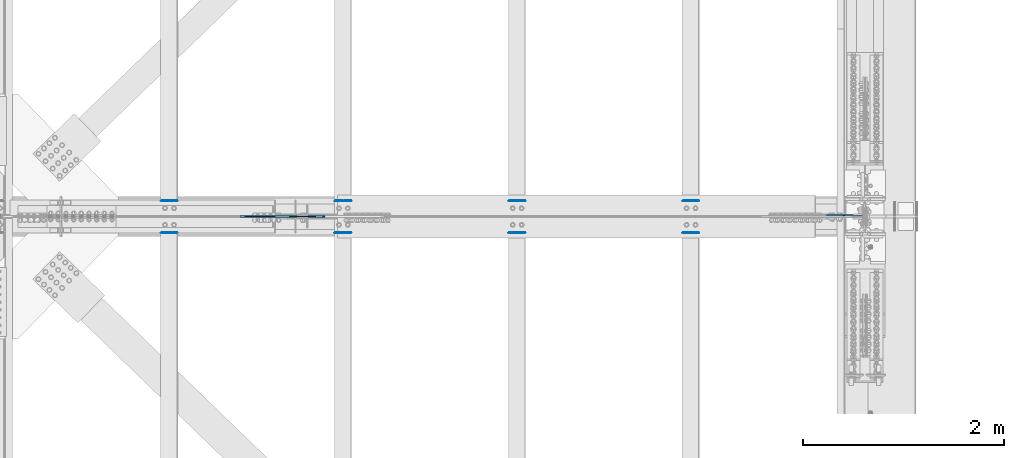
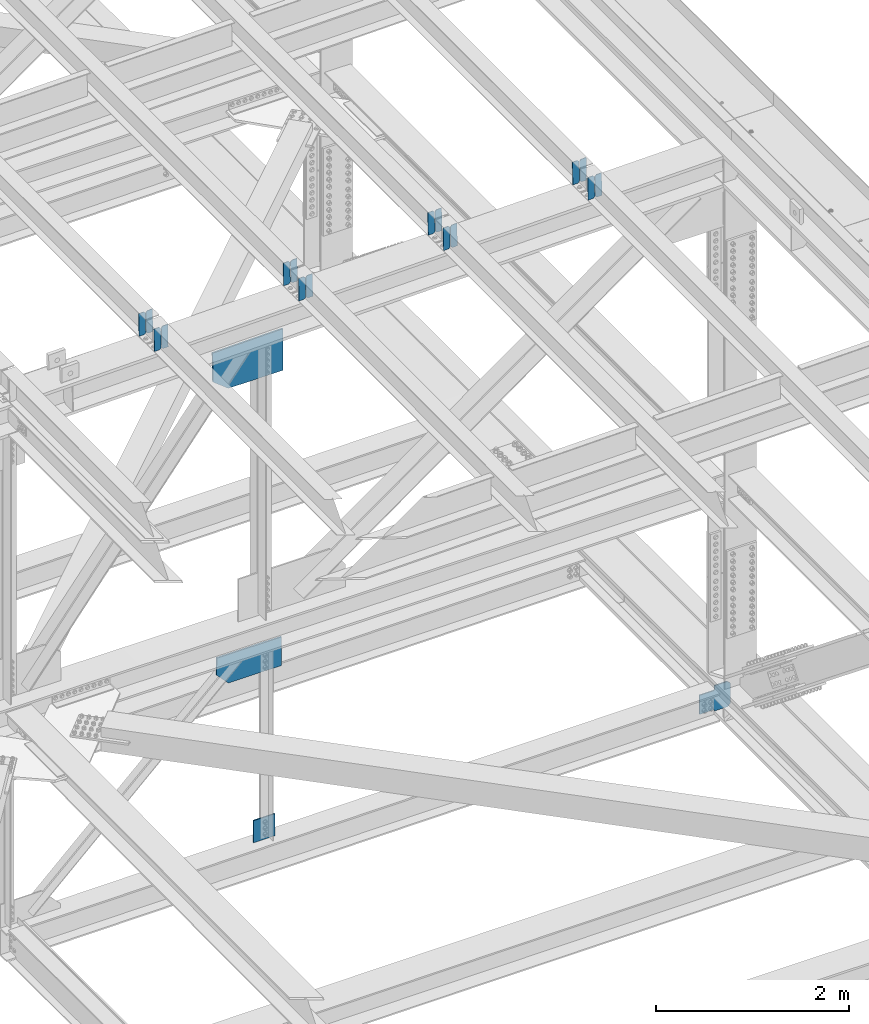
# One storey, part 3592 of 3843: 20 plates, 12 elements without a shape of their own.
"""IFC2X3 building model written with IfcOpenShell, lengths in millimetres."""

from ifc_helpers import new_model, si_unit, frame, origin_with_axes, place, context, subcontext, project, spatial, faceted_brep, material, type_object, element, aggregate, save


model = new_model("IFC2X3")

# Units and contexts
model_context = context("Model", 3, precision=1e-05, world=origin_with_axes())
body_context = subcontext(model_context, "Body", "Model", "MODEL_VIEW")
ifc_project = project(units=[si_unit("LENGTHUNIT", "METRE", prefix="MILLI"), si_unit("AREAUNIT", "SQUARE_METRE"), si_unit("VOLUMEUNIT", "CUBIC_METRE"), si_unit("MASSUNIT", "GRAM", prefix="KILO"), si_unit("TIMEUNIT", "SECOND"), si_unit("PLANEANGLEUNIT", "RADIAN"), si_unit("SOLIDANGLEUNIT", "STERADIAN"), si_unit("THERMODYNAMICTEMPERATUREUNIT", "DEGREE_CELSIUS"), si_unit("LUMINOUSINTENSITYUNIT", "LUMEN")], contexts=[model_context])

# Site, building, storey
site_placement = place(None, origin_with_axes())
site = spatial("IfcSite", under=ifc_project, at=site_placement, CompositionType="ELEMENT")
building_placement = place(site_placement, origin_with_axes())
building = spatial("IfcBuilding", under=site, at=building_placement, Name="Undefined", CompositionType="ELEMENT")
storey_placement = place(building_placement, origin_with_axes())
storey = spatial("IfcBuildingStorey", under=building, at=storey_placement, Name="Undefined", CompositionType="ELEMENT", Elevation=0.0)

# Assembly, plates
assembly_1_placement = place(storey_placement, origin_with_axes())
assembly_1 = element("IfcElementAssembly", 1, at=assembly_1_placement, inside=storey, Name="BEAM", AssemblyPlace="NOTDEFINED", PredefinedType="RIGID_FRAME")
ifc_material = material(Name="STEEL/A572-50")
plate_type_1 = type_object("IfcPlateType", PredefinedType="NOTDEFINED")
plate_1_placement = place(assembly_1_placement, frame((80549.4964783678, 42358.3199648956, 46426.5926528859), z_axis=(-0.0211520975879684, -0.0021646719998389, 0.999773925926638), x_axis=(-0.999776269348977, 4.5491000049241e-05, -0.0211520490073722)))
plate_1 = element("IfcPlate", 2, at=plate_1_placement, type_object=plate_type_1, material=ifc_material, Name="PLATE", context=body_context, shape_type="Brep", body=[
    faceted_brep([(0.0, -3.17499999999927, 0.0), (6.83940015733242e-10, -3.17499999996653, 288.924999998613), (6.54836185276508e-10, 3.17500000001746, 288.924999998591), (0.0, 3.17499999999927, 0.0), (60.3250007643655, -3.17500000017753, 288.924999998606), (60.3250007643219, 3.17499999979918, 288.924999998584), (79.3750000013097, -3.17500000025029, 269.875000761494), (79.375000001266, 3.17499999972642, 269.875000761487), (79.375000000713, -3.17500000026484, 19.0499992370605), (79.3750000006985, 3.17499999971187, 19.0499992370533), (60.325000763667, -3.17500000020664, -1.45519152283669e-11), (60.3250007636234, 3.17499999977736, -3.63797880709171e-11)], [[[0, 1, 2, 3]], [[1, 4, 5, 2]], [[4, 6, 7, 5]], [[6, 8, 9, 7]], [[8, 10, 11, 9]], [[10, 0, 3, 11]], [[5, 7, 9, 11, 3, 2]], [[10, 8, 6, 4, 1, 0]]]),
])
plate_2_placement = place(assembly_1_placement, frame((80463.7906576766, 42358.3238908933, 46424.7793935353), z_axis=(-0.0211520975879684, -0.0021646719998389, 0.999773925926638), x_axis=(-0.999776269348977, 4.5491000049241e-05, -0.0211520490073722)))
plate_2 = element("IfcPlate", 3, at=plate_2_placement, type_object=plate_type_1, material=ifc_material, Name="PLATE", context=body_context, shape_type="Brep", body=[
    faceted_brep([(4.36557456851006e-11, -3.17499999998836, 19.0499992370969), (6.11180439591408e-10, -3.17499999996653, 269.875000761516), (5.96628524363041e-10, 3.17500000001746, 269.875000761502), (1.45519152283669e-11, 3.17499999998836, 19.0499992370824), (19.0499992376572, -3.17500000003201, 288.924999998606), (19.0499992376281, 3.1749999999447, 288.924999998584), (79.3750000013242, -3.17500000025029, 288.924999998591), (79.3750000013097, 3.1749999997337, 288.92499999857), (79.3750000006548, -3.17500000026484, -2.18278728425503e-11), (79.3750000006403, 3.17499999969732, -2.91038304567337e-11), (19.0499992370023, -3.17500000005384, 0.0), (19.0499992369587, 3.17499999992287, -1.45519152283669e-11)], [[[0, 1, 2, 3]], [[1, 4, 5, 2]], [[4, 6, 7, 5]], [[6, 8, 9, 7]], [[8, 10, 11, 9]], [[10, 0, 3, 11]], [[5, 7, 9, 11, 3, 2]], [[10, 8, 6, 4, 1, 0]]]),
])
aggregate(assembly_1, [plate_1, plate_2])

assembly_2_placement = place(storey_placement, origin_with_axes())
assembly_2 = element("IfcElementAssembly", 4, at=assembly_2_placement, inside=storey, Name="BEAM", AssemblyPlace="NOTDEFINED", PredefinedType="RIGID_FRAME")
plate_3_placement = place(assembly_2_placement, frame((80549.4964783593, 42041.8168577056, 46425.3747151897), z_axis=(-0.0211520976960747, -0.00548809500152129, 0.999761206276934), x_axis=(-0.999776269345233, 0.000116185000071389, -0.0211517790072879)))
plate_3 = element("IfcPlate", 5, at=plate_3_placement, type_object=plate_type_1, material=ifc_material, Name="PLATE", context=body_context, shape_type="Brep", body=[
    faceted_brep([(0.0, -3.17499999999927, 0.0), (6.83940015733242e-10, -3.17499999996653, 288.924999998613), (6.54836185276508e-10, 3.17500000001746, 288.924999998591), (0.0, 3.17499999999927, 0.0), (60.3250007643655, -3.17500000017753, 288.924999998606), (60.3250007643219, 3.17499999979918, 288.924999998584), (79.3750000013097, -3.17500000025029, 269.875000761494), (79.375000001266, 3.17499999972642, 269.875000761487), (79.375000000713, -3.17500000026484, 19.0499992370605), (79.3750000006985, 3.17499999971187, 19.0499992370533), (60.325000763667, -3.17500000020664, -1.45519152283669e-11), (60.3250007636234, 3.17499999977736, -3.63797880709171e-11)], [[[0, 1, 2, 3]], [[1, 4, 5, 2]], [[4, 6, 7, 5]], [[6, 8, 9, 7]], [[8, 10, 11, 9]], [[10, 0, 3, 11]], [[5, 7, 9, 11, 3, 2]], [[10, 8, 6, 4, 1, 0]]]),
])
plate_4_placement = place(assembly_2_placement, frame((80463.790657668, 42041.8268112952, 46423.5614789073), z_axis=(-0.0211520976960747, -0.00548809500152129, 0.999761206276934), x_axis=(-0.999776269345233, 0.000116185000071389, -0.0211517790072879)))
plate_4 = element("IfcPlate", 6, at=plate_4_placement, type_object=plate_type_1, material=ifc_material, Name="PLATE", context=body_context, shape_type="Brep", body=[
    faceted_brep([(4.36557456851006e-11, -3.17499999998836, 19.0499992370969), (6.11180439591408e-10, -3.17499999996653, 269.875000761516), (5.96628524363041e-10, 3.17500000001746, 269.875000761502), (1.45519152283669e-11, 3.17499999998836, 19.0499992370824), (19.0499992376572, -3.17500000003201, 288.924999998606), (19.0499992376281, 3.1749999999447, 288.924999998584), (79.3750000013242, -3.17500000025029, 288.924999998591), (79.3750000013097, 3.1749999997337, 288.92499999857), (79.3750000006548, -3.17500000026484, -2.18278728425503e-11), (79.3750000006403, 3.17499999969732, -2.91038304567337e-11), (19.0499992370023, -3.17500000005384, 0.0), (19.0499992369587, 3.17499999992287, -1.45519152283669e-11)], [[[0, 1, 2, 3]], [[1, 4, 5, 2]], [[4, 6, 7, 5]], [[6, 8, 9, 7]], [[8, 10, 11, 9]], [[10, 0, 3, 11]], [[5, 7, 9, 11, 3, 2]], [[10, 8, 6, 4, 1, 0]]]),
])
aggregate(assembly_2, [plate_3, plate_4])

assembly_3_placement = place(storey_placement, origin_with_axes())
assembly_3 = element("IfcElementAssembly", 7, at=assembly_3_placement, inside=storey, Name="BEAM", AssemblyPlace="NOTDEFINED", PredefinedType="RIGID_FRAME")
plate_5_placement = place(assembly_3_placement, frame((84003.8964783664, 42358.3091470326, 46491.0935122298), z_axis=(-0.0211520979367197, -0.00212832399991021, 0.999774003957808), x_axis=(-0.999776269348977, 4.5491000049241e-05, -0.0211520490073722)))
plate_5 = element("IfcPlate", 8, at=plate_5_placement, type_object=plate_type_1, material=ifc_material, Name="PLATE", context=body_context, shape_type="Brep", body=[
    faceted_brep([(0.0, -3.17499999999927, 0.0), (6.83940015733242e-10, -3.17499999996653, 288.924999998613), (6.54836185276508e-10, 3.17500000001746, 288.924999998591), (0.0, 3.17499999999927, 0.0), (60.3250007643655, -3.17500000017753, 288.924999998606), (60.3250007643219, 3.17499999979918, 288.924999998584), (79.3750000013097, -3.17500000025029, 269.875000761494), (79.375000001266, 3.17499999972642, 269.875000761487), (79.375000000713, -3.17500000026484, 19.0499992370605), (79.3750000006985, 3.17499999971187, 19.0499992370533), (60.325000763667, -3.17500000020664, -1.45519152283669e-11), (60.3250007636234, 3.17499999977736, -3.63797880709171e-11)], [[[0, 1, 2, 3]], [[1, 4, 5, 2]], [[4, 6, 7, 5]], [[6, 8, 9, 7]], [[8, 10, 11, 9]], [[10, 0, 3, 11]], [[5, 7, 9, 11, 3, 2]], [[10, 8, 6, 4, 1, 0]]]),
])
plate_6_placement = place(assembly_3_placement, frame((83918.1906576753, 42358.3130071105, 46489.2802527375), z_axis=(-0.0211520979367197, -0.00212832399991021, 0.999774003957808), x_axis=(-0.999776269348977, 4.5491000049241e-05, -0.0211520490073722)))
plate_6 = element("IfcPlate", 9, at=plate_6_placement, type_object=plate_type_1, material=ifc_material, Name="PLATE", context=body_context, shape_type="Brep", body=[
    faceted_brep([(4.36557456851006e-11, -3.17499999998836, 19.0499992370969), (6.11180439591408e-10, -3.17499999996653, 269.875000761516), (5.96628524363041e-10, 3.17500000001746, 269.875000761502), (1.45519152283669e-11, 3.17499999998836, 19.0499992370824), (19.0499992376572, -3.17500000003201, 288.924999998606), (19.0499992376281, 3.1749999999447, 288.924999998584), (79.3750000013242, -3.17500000025029, 288.924999998591), (79.3750000013097, 3.1749999997337, 288.92499999857), (79.3750000006548, -3.17500000026484, -2.18278728425503e-11), (79.3750000006403, 3.17499999969732, -2.91038304567337e-11), (19.0499992370023, -3.17500000005384, 0.0), (19.0499992369587, 3.17499999992287, -1.45519152283669e-11)], [[[0, 1, 2, 3]], [[1, 4, 5, 2]], [[4, 6, 7, 5]], [[6, 8, 9, 7]], [[8, 10, 11, 9]], [[10, 0, 3, 11]], [[5, 7, 9, 11, 3, 2]], [[10, 8, 6, 4, 1, 0]]]),
])
aggregate(assembly_3, [plate_5, plate_6])

assembly_4_placement = place(storey_placement, origin_with_axes())
assembly_4 = element("IfcElementAssembly", 10, at=assembly_4_placement, inside=storey, Name="BEAM", AssemblyPlace="NOTDEFINED", PredefinedType="RIGID_FRAME")
plate_7_placement = place(assembly_4_placement, frame((84003.8964783501, 42041.4395259764, 46490.0840868049), z_axis=(-0.0211520977821637, -0.00421267500005342, 0.999767394011606), x_axis=(-0.999776269352005, 8.91270000423765e-05, -0.0211519100074729)))
plate_7 = element("IfcPlate", 11, at=plate_7_placement, type_object=plate_type_1, material=ifc_material, Name="PLATE", context=body_context, shape_type="Brep", body=[
    faceted_brep([(0.0, -3.17499999999927, 0.0), (6.83940015733242e-10, -3.17499999996653, 288.924999998613), (6.54836185276508e-10, 3.17500000001746, 288.924999998591), (0.0, 3.17499999999927, 0.0), (60.3250007643655, -3.17500000017753, 288.924999998606), (60.3250007643219, 3.17499999979918, 288.924999998584), (79.3750000013097, -3.17500000025029, 269.875000761494), (79.375000001266, 3.17499999972642, 269.875000761487), (79.375000000713, -3.17500000026484, 19.0499992370605), (79.3750000006985, 3.17499999971187, 19.0499992370533), (60.325000763667, -3.17500000020664, -1.45519152283669e-11), (60.3250007636234, 3.17499999977736, -3.63797880709171e-11)], [[[0, 1, 2, 3]], [[1, 4, 5, 2]], [[4, 6, 7, 5]], [[6, 8, 9, 7]], [[8, 10, 11, 9]], [[10, 0, 3, 11]], [[5, 7, 9, 11, 3, 2]], [[10, 8, 6, 4, 1, 0]]]),
])
plate_8_placement = place(assembly_4_placement, frame((83918.1906576589, 42041.4471663751, 46488.2708393004), z_axis=(-0.0211520977821637, -0.00421267500005342, 0.999767394011606), x_axis=(-0.999776269352005, 8.91270000423765e-05, -0.0211519100074729)))
plate_8 = element("IfcPlate", 12, at=plate_8_placement, type_object=plate_type_1, material=ifc_material, Name="PLATE", context=body_context, shape_type="Brep", body=[
    faceted_brep([(4.36557456851006e-11, -3.17499999998836, 19.0499992370969), (6.11180439591408e-10, -3.17499999996653, 269.875000761516), (5.96628524363041e-10, 3.17500000001746, 269.875000761502), (1.45519152283669e-11, 3.17499999998836, 19.0499992370824), (19.0499992376572, -3.17500000003201, 288.924999998606), (19.0499992376281, 3.1749999999447, 288.924999998584), (79.3750000013242, -3.17500000025029, 288.924999998591), (79.3750000013097, 3.1749999997337, 288.92499999857), (79.3750000006548, -3.17500000026484, -2.18278728425503e-11), (79.3750000006403, 3.17499999969732, -2.91038304567337e-11), (19.0499992370023, -3.17500000005384, 0.0), (19.0499992369587, 3.17499999992287, -1.45519152283669e-11)], [[[0, 1, 2, 3]], [[1, 4, 5, 2]], [[4, 6, 7, 5]], [[6, 8, 9, 7]], [[8, 10, 11, 9]], [[10, 0, 3, 11]], [[5, 7, 9, 11, 3, 2]], [[10, 8, 6, 4, 1, 0]]]),
])
aggregate(assembly_4, [plate_7, plate_8])

assembly_5_placement = place(storey_placement, origin_with_axes())
assembly_5 = element("IfcElementAssembly", 13, at=assembly_5_placement, inside=storey, Name="BEAM", AssemblyPlace="NOTDEFINED", PredefinedType="RIGID_FRAME")
plate_9_placement = place(assembly_5_placement, frame((82276.6964783747, 42358.315649763, 46459.089393247), z_axis=(-0.0211520979252964, -0.00215017300044565, 0.999773957207041), x_axis=(-0.999776269348977, 4.5491000049241e-05, -0.0211520490073722)))
plate_9 = element("IfcPlate", 14, at=plate_9_placement, type_object=plate_type_1, material=ifc_material, Name="PLATE", context=body_context, shape_type="Brep", body=[
    faceted_brep([(0.0, -3.17499999999927, 0.0), (6.83940015733242e-10, -3.17499999996653, 288.924999998613), (6.54836185276508e-10, 3.17500000001746, 288.924999998591), (0.0, 3.17499999999927, 0.0), (60.3250007643655, -3.17500000017753, 288.924999998606), (60.3250007643219, 3.17499999979918, 288.924999998584), (79.3750000013097, -3.17500000025029, 269.875000761494), (79.375000001266, 3.17499999972642, 269.875000761487), (79.375000000713, -3.17500000026484, 19.0499992370605), (79.3750000006985, 3.17499999971187, 19.0499992370533), (60.325000763667, -3.17500000020664, -1.45519152283669e-11), (60.3250007636234, 3.17499999977736, -3.63797880709171e-11)], [[[0, 1, 2, 3]], [[1, 4, 5, 2]], [[4, 6, 7, 5]], [[6, 8, 9, 7]], [[8, 10, 11, 9]], [[10, 0, 3, 11]], [[5, 7, 9, 11, 3, 2]], [[10, 8, 6, 4, 1, 0]]]),
])
plate_10_placement = place(assembly_5_placement, frame((82190.9906576834, 42358.3195494665, 46457.276133839), z_axis=(-0.0211520979252964, -0.00215017300044565, 0.999773957207041), x_axis=(-0.999776269348977, 4.5491000049241e-05, -0.0211520490073722)))
plate_10 = element("IfcPlate", 15, at=plate_10_placement, type_object=plate_type_1, material=ifc_material, Name="PLATE", context=body_context, shape_type="Brep", body=[
    faceted_brep([(4.36557456851006e-11, -3.17499999998836, 19.0499992370969), (6.11180439591408e-10, -3.17499999996653, 269.875000761516), (5.96628524363041e-10, 3.17500000001746, 269.875000761502), (1.45519152283669e-11, 3.17499999998836, 19.0499992370824), (19.0499992376572, -3.17500000003201, 288.924999998606), (19.0499992376281, 3.1749999999447, 288.924999998584), (79.3750000013242, -3.17500000025029, 288.924999998591), (79.3750000013097, 3.1749999997337, 288.92499999857), (79.3750000006548, -3.17500000026484, -2.18278728425503e-11), (79.3750000006403, 3.17499999969732, -2.91038304567337e-11), (19.0499992370023, -3.17500000005384, 0.0), (19.0499992369587, 3.17499999992287, -1.45519152283669e-11)], [[[0, 1, 2, 3]], [[1, 4, 5, 2]], [[4, 6, 7, 5]], [[6, 8, 9, 7]], [[8, 10, 11, 9]], [[10, 0, 3, 11]], [[5, 7, 9, 11, 3, 2]], [[10, 8, 6, 4, 1, 0]]]),
])
aggregate(assembly_5, [plate_9, plate_10])

assembly_6_placement = place(storey_placement, origin_with_axes())
assembly_6 = element("IfcElementAssembly", 16, at=assembly_6_placement, inside=storey, Name="BEAM", AssemblyPlace="NOTDEFINED", PredefinedType="RIGID_FRAME")
plate_11_placement = place(assembly_6_placement, frame((82276.6964783656, 42041.6344004031, 46457.9703275684), z_axis=(-0.0211520979626948, -0.00487978700220265, 0.999764360452297), x_axis=(-0.999776269348186, 0.0001032410000617, -0.0211518460073737)))
plate_11 = element("IfcPlate", 17, at=plate_11_placement, type_object=plate_type_1, material=ifc_material, Name="PLATE", context=body_context, shape_type="Brep", body=[
    faceted_brep([(0.0, -3.17499999999927, 0.0), (6.83940015733242e-10, -3.17499999996653, 288.924999998613), (6.54836185276508e-10, 3.17500000001746, 288.924999998591), (0.0, 3.17499999999927, 0.0), (60.3250007643655, -3.17500000017753, 288.924999998606), (60.3250007643219, 3.17499999979918, 288.924999998584), (79.3750000013097, -3.17500000025029, 269.875000761494), (79.375000001266, 3.17499999972642, 269.875000761487), (79.375000000713, -3.17500000026484, 19.0499992370605), (79.3750000006985, 3.17499999971187, 19.0499992370533), (60.325000763667, -3.17500000020664, -1.45519152283669e-11), (60.3250007636234, 3.17499999977736, -3.63797880709171e-11)], [[[0, 1, 2, 3]], [[1, 4, 5, 2]], [[4, 6, 7, 5]], [[6, 8, 9, 7]], [[8, 10, 11, 9]], [[10, 0, 3, 11]], [[5, 7, 9, 11, 3, 2]], [[10, 8, 6, 4, 1, 0]]]),
])
plate_12_placement = place(assembly_6_placement, frame((82190.9906576744, 42041.6432507236, 46456.1570855647), z_axis=(-0.0211520979626948, -0.00487978700220265, 0.999764360452297), x_axis=(-0.999776269348186, 0.0001032410000617, -0.0211518460073737)))
plate_12 = element("IfcPlate", 18, at=plate_12_placement, type_object=plate_type_1, material=ifc_material, Name="PLATE", context=body_context, shape_type="Brep", body=[
    faceted_brep([(4.36557456851006e-11, -3.17499999998836, 19.0499992370969), (6.11180439591408e-10, -3.17499999996653, 269.875000761516), (5.96628524363041e-10, 3.17500000001746, 269.875000761502), (1.45519152283669e-11, 3.17499999998836, 19.0499992370824), (19.0499992376572, -3.17500000003201, 288.924999998606), (19.0499992376281, 3.1749999999447, 288.924999998584), (79.3750000013242, -3.17500000025029, 288.924999998591), (79.3750000013097, 3.1749999997337, 288.92499999857), (79.3750000006548, -3.17500000026484, -2.18278728425503e-11), (79.3750000006403, 3.17499999969732, -2.91038304567337e-11), (19.0499992370023, -3.17500000005384, 0.0), (19.0499992369587, 3.17499999992287, -1.45519152283669e-11)], [[[0, 1, 2, 3]], [[1, 4, 5, 2]], [[4, 6, 7, 5]], [[6, 8, 9, 7]], [[8, 10, 11, 9]], [[10, 0, 3, 11]], [[5, 7, 9, 11, 3, 2]], [[10, 8, 6, 4, 1, 0]]]),
])
aggregate(assembly_6, [plate_11, plate_12])

assembly_7_placement = place(storey_placement, origin_with_axes())
assembly_7 = element("IfcElementAssembly", 19, at=assembly_7_placement, inside=storey, Name="BEAM", AssemblyPlace="NOTDEFINED", PredefinedType="RIGID_FRAME")
plate_13_placement = place(assembly_7_placement, frame((78822.2964783704, 42358.3510876909, 46392.8041595779), z_axis=(-0.0211520984925882, -0.00226925499999197, 0.999773693998349), x_axis=(-0.999776269336975, 4.80100000080746e-05, -0.0211520440071395)))
plate_13 = element("IfcPlate", 20, at=plate_13_placement, type_object=plate_type_1, material=ifc_material, Name="PLATE", context=body_context, shape_type="Brep", body=[
    faceted_brep([(0.0, -3.17499999999927, 0.0), (6.83940015733242e-10, -3.17499999996653, 288.924999998613), (6.54836185276508e-10, 3.17500000001746, 288.924999998591), (0.0, 3.17499999999927, 0.0), (60.3250007643655, -3.17500000017753, 288.924999998606), (60.3250007643219, 3.17499999979918, 288.924999998584), (79.3750000013097, -3.17500000025029, 269.875000761494), (79.375000001266, 3.17499999972642, 269.875000761487), (79.375000000713, -3.17500000026484, 19.0499992370605), (79.3750000006985, 3.17499999971187, 19.0499992370533), (60.325000763667, -3.17500000020664, -1.45519152283669e-11), (60.3250007636234, 3.17499999977736, -3.63797880709171e-11)], [[[0, 1, 2, 3]], [[1, 4, 5, 2]], [[4, 6, 7, 5]], [[6, 8, 9, 7]], [[8, 10, 11, 9]], [[10, 0, 3, 11]], [[5, 7, 9, 11, 3, 2]], [[10, 8, 6, 4, 1, 0]]]),
])
plate_14_placement = place(assembly_7_placement, frame((78736.5906576792, 42358.3552033693, 46390.9909006472), z_axis=(-0.0211520984925882, -0.00226925499999197, 0.999773693998349), x_axis=(-0.999776269336975, 4.80100000080746e-05, -0.0211520440071395)))
plate_14 = element("IfcPlate", 21, at=plate_14_placement, type_object=plate_type_1, material=ifc_material, Name="PLATE", context=body_context, shape_type="Brep", body=[
    faceted_brep([(4.36557456851006e-11, -3.17499999998836, 19.0499992370969), (6.11180439591408e-10, -3.17499999996653, 269.875000761516), (5.96628524363041e-10, 3.17500000001746, 269.875000761502), (1.45519152283669e-11, 3.17499999998836, 19.0499992370824), (19.0499992376572, -3.17500000003201, 288.924999998606), (19.0499992376281, 3.1749999999447, 288.924999998584), (79.3750000013242, -3.17500000025029, 288.924999998591), (79.3750000013097, 3.1749999997337, 288.92499999857), (79.3750000006548, -3.17500000026484, -2.18278728425503e-11), (79.3750000006403, 3.17499999969732, -2.91038304567337e-11), (19.0499992370023, -3.17500000005384, 0.0), (19.0499992369587, 3.17499999992287, -1.45519152283669e-11)], [[[0, 1, 2, 3]], [[1, 4, 5, 2]], [[4, 6, 7, 5]], [[6, 8, 9, 7]], [[8, 10, 11, 9]], [[10, 0, 3, 11]], [[5, 7, 9, 11, 3, 2]], [[10, 8, 6, 4, 1, 0]]]),
])
aggregate(assembly_7, [plate_13, plate_14])

assembly_8_placement = place(storey_placement, origin_with_axes())
assembly_8 = element("IfcElementAssembly", 22, at=assembly_8_placement, inside=storey, Name="BEAM", AssemblyPlace="NOTDEFINED", PredefinedType="RIGID_FRAME")
plate_15_placement = place(assembly_8_placement, frame((78822.2964783586, 42041.9151235253, 46391.5178998014), z_axis=(-0.0211520978613553, -0.0058155520005821, 0.999759355100512), x_axis=(-0.99977626935033, 0.000123039000078619, -0.0211517400074097)))
plate_15 = element("IfcPlate", 23, at=plate_15_placement, type_object=plate_type_1, material=ifc_material, Name="PLATE", context=body_context, shape_type="Brep", body=[
    faceted_brep([(0.0, -3.17499999999927, 0.0), (6.83940015733242e-10, -3.17499999996653, 288.924999998613), (6.54836185276508e-10, 3.17500000001746, 288.924999998591), (0.0, 3.17499999999927, 0.0), (60.3250007643655, -3.17500000017753, 288.924999998606), (60.3250007643219, 3.17499999979918, 288.924999998584), (79.3750000013097, -3.17500000025029, 269.875000761494), (79.375000001266, 3.17499999972642, 269.875000761487), (79.375000000713, -3.17500000026484, 19.0499992370605), (79.3750000006985, 3.17499999971187, 19.0499992370533), (60.325000763667, -3.17500000020664, -1.45519152283669e-11), (60.3250007636234, 3.17499999977736, -3.63797880709171e-11)], [[[0, 1, 2, 3]], [[1, 4, 5, 2]], [[4, 6, 7, 5]], [[6, 8, 9, 7]], [[8, 10, 11, 9]], [[10, 0, 3, 11]], [[5, 7, 9, 11, 3, 2]], [[10, 8, 6, 4, 1, 0]]]),
])
plate_16_placement = place(assembly_8_placement, frame((78736.5906576673, 42041.9256710129, 46389.7046668775), z_axis=(-0.0211520978613553, -0.0058155520005821, 0.999759355100512), x_axis=(-0.99977626935033, 0.000123039000078619, -0.0211517400074097)))
plate_16 = element("IfcPlate", 24, at=plate_16_placement, type_object=plate_type_1, material=ifc_material, Name="PLATE", context=body_context, shape_type="Brep", body=[
    faceted_brep([(4.36557456851006e-11, -3.17499999998836, 19.0499992370969), (6.11180439591408e-10, -3.17499999996653, 269.875000761516), (5.96628524363041e-10, 3.17500000001746, 269.875000761502), (1.45519152283669e-11, 3.17499999998836, 19.0499992370824), (19.0499992376572, -3.17500000003201, 288.924999998606), (19.0499992376281, 3.1749999999447, 288.924999998584), (79.3750000013242, -3.17500000025029, 288.924999998591), (79.3750000013097, 3.1749999997337, 288.92499999857), (79.3750000006548, -3.17500000026484, -2.18278728425503e-11), (79.3750000006403, 3.17499999969732, -2.91038304567337e-11), (19.0499992370023, -3.17500000005384, 0.0), (19.0499992369587, 3.17499999992287, -1.45519152283669e-11)], [[[0, 1, 2, 3]], [[1, 4, 5, 2]], [[4, 6, 7, 5]], [[6, 8, 9, 7]], [[8, 10, 11, 9]], [[10, 0, 3, 11]], [[5, 7, 9, 11, 3, 2]], [[10, 8, 6, 4, 1, 0]]]),
])
aggregate(assembly_8, [plate_15, plate_16])

# Assembly, plate
assembly_9_placement = place(storey_placement, origin_with_axes())
assembly_9 = element("IfcElementAssembly", 25, at=assembly_9_placement, inside=storey, Name="BEAM", AssemblyPlace="NOTDEFINED", PredefinedType="RIGID_FRAME")
plate_type_2 = type_object("IfcPlateType", PredefinedType="NOTDEFINED")
plate_17_placement = place(assembly_9_placement, frame((85633.7187500008, 42213.8078140904, 39402.2210354695), z_axis=(-0.707106781186548, 0.0, 0.707106781186548), x_axis=(-0.707106781186548, 0.0, -0.707106781186548)))
plate_17 = element("IfcPlate", 26, at=plate_17_placement, type_object=plate_type_2, material=ifc_material, Name="PLATE", context=body_context, shape_type="Brep", body=[
    faceted_brep([(0.0, -6.3499999046162, 0.0), (-180.70345813263, -6.35000000000582, 180.703458132633), (-180.70345813263, 6.35000000000582, 180.703458132633), (7.27595761418343e-12, 6.3499999046162, 0.0), (-180.703458132164, -6.35000000000582, 225.604738738228), (-180.703458132164, 6.35000000000582, 225.604738738228), (-70.1340546331339, -6.35000000000582, 336.174142237258), (-70.1340546331339, 6.35000000000582, 336.174142237258), (-37.5835152634099, -6.34999999999854, 303.623602856704), (-37.5835152634099, 6.34999999999854, 303.623602856704), (-33.4633387952636, -6.34999999999854, 300.870588956237), (-33.4633387952636, 6.34999999999854, 300.870588956237), (-28.6032592771953, -6.34999999999854, 299.903859033675), (-28.6032592771953, 6.34999999999854, 299.903859033675), (-23.7431797591416, -6.34999999999854, 300.870588956288), (-23.7431797591416, 6.34999999999854, 300.870588956288), (-19.6230032909662, -6.34999999999854, 303.623602856791), (-19.6230032909662, 6.34999999999854, 303.623602856791), (97.1203264185024, -6.34999999999854, 420.366932566274), (97.1203264185024, 6.34999999999854, 420.366932566274), (267.745192718008, -6.34999999999854, 249.74206626679), (267.745192718008, 6.34999999999854, 249.74206626679), (151.001863008525, -6.34999999999854, 132.998736557303), (151.001863008525, 6.34999999999854, 132.998736557303), (148.248849108015, -6.34999999999854, 128.878560089128), (148.248849108015, 6.34999999999854, 128.878560089128), (147.282119185402, -6.34999999999854, 124.01848057106), (147.282119185402, 6.34999999999854, 124.01848057106), (148.248849107971, -6.34999999999854, 119.158401053006), (148.248849107971, 6.34999999999854, 119.158401053006), (151.001863008423, -6.34999999999854, 115.038224584852), (151.001863008423, 6.34999999999854, 115.038224584852), (155.470684068496, -6.35000000000582, 110.569403464237), (155.470684068496, 6.35000000000582, 110.569403464237), (44.9012806051323, -6.35000000000582, -1.45519152283669e-11), (44.9012806051323, 6.35000000000582, -1.45519152283669e-11)], [[[0, 1, 2, 3]], [[1, 4, 5, 2]], [[4, 6, 7, 5]], [[6, 8, 9, 7]], [[8, 10, 11, 9]], [[10, 12, 13, 11]], [[12, 14, 15, 13]], [[14, 16, 17, 15]], [[16, 18, 19, 17]], [[18, 20, 21, 19]], [[20, 22, 23, 21]], [[22, 24, 25, 23]], [[24, 26, 27, 25]], [[26, 28, 29, 27]], [[28, 30, 31, 29]], [[30, 32, 33, 31]], [[32, 34, 35, 33]], [[34, 0, 3, 35]], [[5, 7, 9, 11, 13, 15, 17, 19, 21, 23, 25, 27, 29, 31, 33, 35, 3, 2]], [[34, 32, 30, 28, 26, 24, 22, 20, 18, 16, 14, 12, 10, 8, 6, 4, 1, 0]]]),
])
aggregate(assembly_9, [plate_17])

assembly_10_placement = place(storey_placement, origin_with_axes())
assembly_10 = element("IfcElementAssembly", 27, at=assembly_10_placement, inside=storey, Name="BEAM", AssemblyPlace="NOTDEFINED", PredefinedType="RIGID_FRAME")
plate_type_3 = type_object("IfcPlateType", PredefinedType="NOTDEFINED")
plate_18_placement = place(assembly_10_placement, frame((80264.0016667448, 42202.1, 42129.2708900642), z_axis=(-0.0020995939996792, 0.0, -0.999997795850089), x_axis=(-0.999997795850089, 0.0, 0.00209959399968341)))
plate_18 = element("IfcPlate", 28, at=plate_18_placement, type_object=plate_type_3, material=ifc_material, Name="PLATE", context=body_context, shape_type="Brep", body=[
    faceted_brep([(0.0, -9.52500000000146, 0.0), (-0.756188136219862, -9.52500000000146, 360.952224277426), (-0.756188136219862, 9.52500000000146, 360.952224277426), (0.0, 9.52500000000146, 0.0), (634.075406665463, -9.52500000000146, 362.262078985717), (634.075406665463, 9.52500000000146, 362.262078985717), (773.627277937543, -9.52500000000146, 214.561313136626), (773.627277937543, 9.52500000000146, 214.561313136626), (773.627277937572, -9.52500000000146, 1.67347025126219e-10), (773.627277937572, 9.52500000000146, 1.67347025126219e-10)], [[[0, 1, 2, 3]], [[1, 4, 5, 2]], [[4, 6, 7, 5]], [[6, 8, 9, 7]], [[8, 0, 3, 9]], [[5, 7, 9, 3, 2]], [[8, 6, 4, 1, 0]]]),
])
aggregate(assembly_10, [plate_18])

assembly_11_placement = place(storey_placement, origin_with_axes())
assembly_11 = element("IfcElementAssembly", 29, at=assembly_11_placement, inside=storey, Name="BEAM", AssemblyPlace="NOTDEFINED", PredefinedType="RIGID_FRAME")
plate_type_4 = type_object("IfcPlateType", PredefinedType="NOTDEFINED")
plate_19_placement = place(assembly_11_placement, frame((80279.5348252372, 42202.1, 46016.217310088), z_axis=(0.0190473820031184, 0.0, -0.999818582163198), x_axis=(-0.999818582163198, 0.0, -0.0190473820031122)))
plate_19 = element("IfcPlate", 30, at=plate_19_placement, type_object=plate_type_4, material=ifc_material, Name="PLATE", context=body_context, shape_type="Brep", body=[
    faceted_brep([(0.0, -9.52500000000146, 0.0), (9.65693940823257, -9.52500000000146, 524.763043083636), (9.65693940823257, 9.52500000000146, 524.763043083636), (0.0, 9.52500000000146, 0.0), (661.814282067062, -9.52500000000146, 512.338898926799), (661.814282067062, 9.52500000000146, 512.338898926799), (839.022931299158, -9.52500000000146, 367.926102829544), (839.022931299158, 9.52500000000146, 367.926102829544), (839.022931294137, -9.52500000000146, 6.83212419971824e-09), (839.022931294137, 9.52500000000146, 6.83212419971824e-09)], [[[0, 1, 2, 3]], [[1, 4, 5, 2]], [[4, 6, 7, 5]], [[6, 8, 9, 7]], [[8, 0, 3, 9]], [[5, 7, 9, 3, 2]], [[8, 6, 4, 1, 0]]]),
])
aggregate(assembly_11, [plate_19])

assembly_12_placement = place(storey_placement, origin_with_axes())
assembly_12 = element("IfcElementAssembly", 31, at=assembly_12_placement, inside=storey, Name="BEAM", AssemblyPlace="NOTDEFINED", PredefinedType="RIGID_FRAME")
plate_type_5 = type_object("IfcPlateType", PredefinedType="NOTDEFINED")
plate_20_placement = place(assembly_12_placement, frame((80189.4857826413, 42202.1000007629, 39643.8196452022), z_axis=(-0.00604360400156291, 0.0, 0.999981737258572), x_axis=(-0.999981737258572, 0.0, -0.00604360400156005)))
plate_20 = element("IfcPlate", 32, at=plate_20_placement, type_object=plate_type_5, material=ifc_material, Name="PLATE", context=body_context, shape_type="Brep", body=[
    faceted_brep([(0.0, -6.3499999046162, 0.0), (1.68802216649055e-09, -6.35000000000582, 278.934838651556), (1.68802216649055e-09, 6.35000000000582, 278.934838651556), (7.27595761418343e-12, 6.3499999046162, 0.0), (253.995361635985, -6.35000000000582, 280.469914072346), (253.995361635985, 6.35000000000582, 280.469914072346), (255.690441688173, -6.35000000000582, 3.34694050252438e-10), (255.690441688173, 6.35000000000582, 3.34694050252438e-10)], [[[0, 1, 2, 3]], [[1, 4, 5, 2]], [[4, 6, 7, 5]], [[6, 0, 3, 7]], [[5, 7, 3, 2]], [[6, 4, 1, 0]]]),
])
aggregate(assembly_12, [plate_20])

save(model, "model.ifc")
